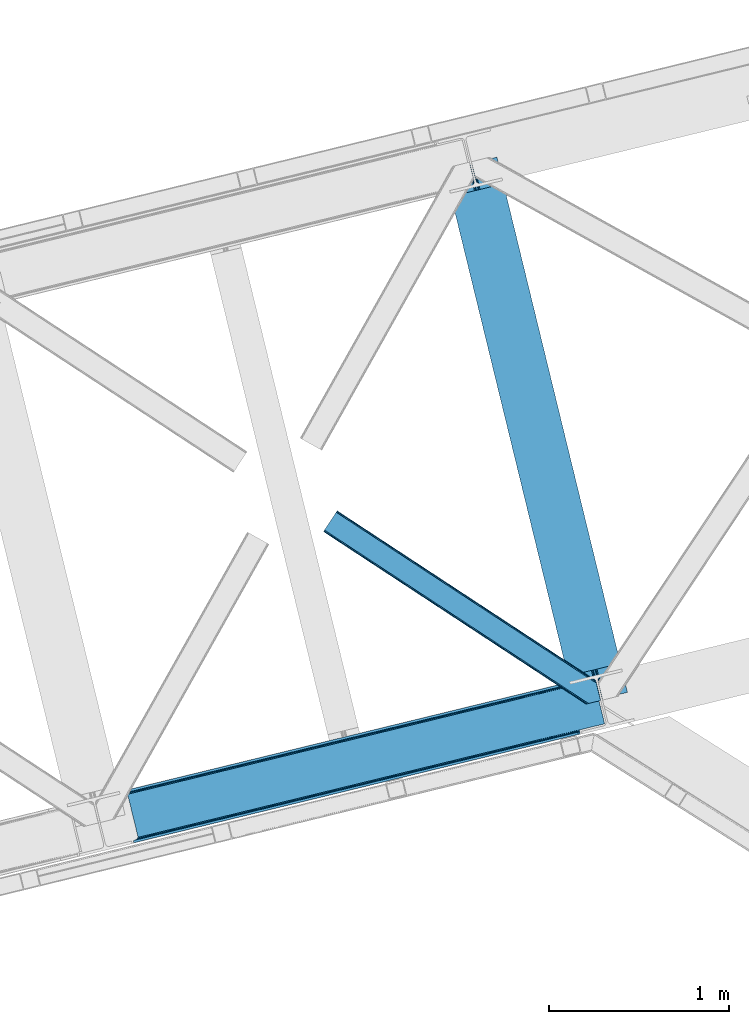
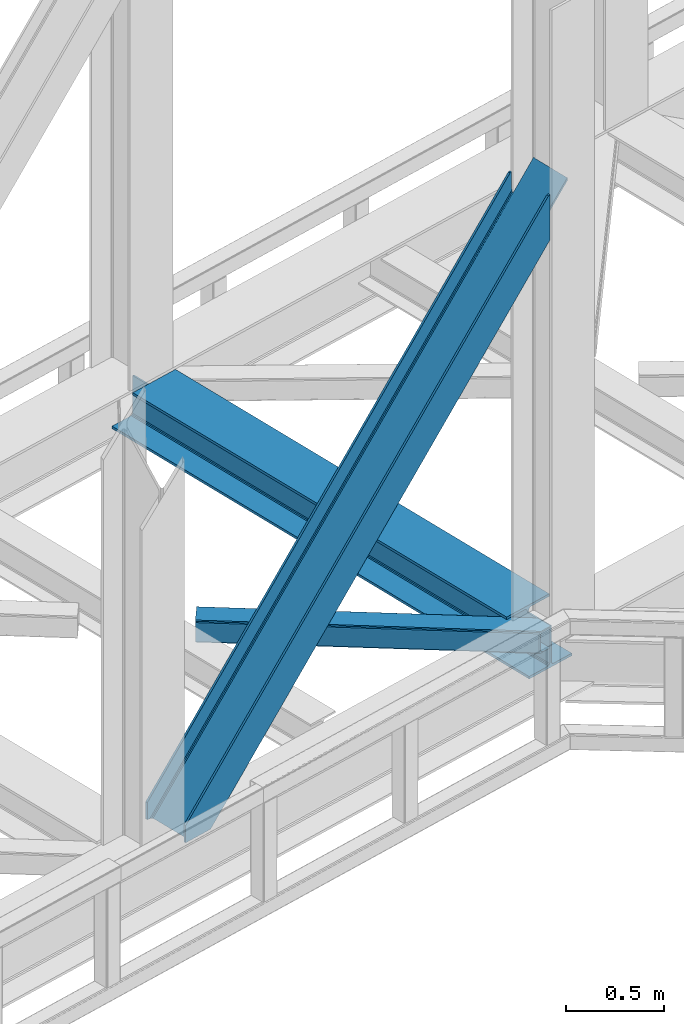
# One storey, part 80 of 92: 2 members, 1 beam.
"""IFC4 building model written with IfcOpenShell, lengths in millimetres."""

from ifc_helpers import new_model, entity, si_unit, converted_unit, derived_unit, direction, frame, origin, place, context, subcontext, project, spatial, triangles, polygons, material, type_object, element, save


model = new_model("IFC4")

# Units and contexts
model_context = context("Model", 3, precision=0.01, world=origin(), true_north=direction((6.12303176911189e-17, 1.0)))
plan_context = context("Plan", 3, precision=0.01, world=origin(), true_north=direction((6.12303176911189e-17, 1.0)))
body_context = subcontext(model_context, "Body", "Model", "MODEL_VIEW")
ifc_project = project(units=[si_unit("LENGTHUNIT", "METRE", prefix="MILLI"), si_unit("AREAUNIT", "SQUARE_METRE"), si_unit("VOLUMEUNIT", "CUBIC_METRE"), converted_unit("PLANEANGLEUNIT", "DEGREE", entity("IfcRatioMeasure", 0.0174532925199433), si_unit("PLANEANGLEUNIT", "RADIAN"), dimensions=[0, 0, 0, 0, 0, 0, 0]), si_unit("MASSUNIT", "GRAM", prefix="KILO"), derived_unit("MASSDENSITYUNIT", [(si_unit("MASSUNIT", "GRAM", prefix="KILO"), 1), (si_unit("LENGTHUNIT", "METRE"), -3)]), derived_unit("MOMENTOFINERTIAUNIT", [(si_unit("LENGTHUNIT", "METRE"), 4)]), si_unit("TIMEUNIT", "SECOND"), si_unit("FREQUENCYUNIT", "HERTZ"), si_unit("THERMODYNAMICTEMPERATUREUNIT", "DEGREE_CELSIUS"), derived_unit("THERMALTRANSMITTANCEUNIT", [(si_unit("MASSUNIT", "GRAM", prefix="KILO"), 1), (si_unit("THERMODYNAMICTEMPERATUREUNIT", "KELVIN"), -1), (si_unit("TIMEUNIT", "SECOND"), -3)]), derived_unit("VOLUMETRICFLOWRATEUNIT", [(si_unit("LENGTHUNIT", "METRE"), 3), (si_unit("TIMEUNIT", "SECOND"), -1)]), derived_unit("MASSFLOWRATEUNIT", [(si_unit("MASSUNIT", "GRAM", prefix="KILO"), 1), (si_unit("TIMEUNIT", "SECOND"), -1)]), derived_unit("ROTATIONALFREQUENCYUNIT", [(si_unit("TIMEUNIT", "SECOND"), -1)]), si_unit("ELECTRICCURRENTUNIT", "AMPERE"), si_unit("ELECTRICVOLTAGEUNIT", "VOLT"), si_unit("POWERUNIT", "WATT"), si_unit("FORCEUNIT", "NEWTON", prefix="KILO"), si_unit("ILLUMINANCEUNIT", "LUX"), si_unit("LUMINOUSFLUXUNIT", "LUMEN"), si_unit("LUMINOUSINTENSITYUNIT", "CANDELA"), derived_unit("USERDEFINED", [(si_unit("MASSUNIT", "GRAM", prefix="KILO"), -1), (si_unit("LENGTHUNIT", "METRE"), -2), (si_unit("TIMEUNIT", "SECOND"), 3), (si_unit("LUMINOUSFLUXUNIT", "LUMEN"), 1)]), derived_unit("LINEARVELOCITYUNIT", [(si_unit("LENGTHUNIT", "METRE"), 1), (si_unit("TIMEUNIT", "SECOND"), -1)]), si_unit("PRESSUREUNIT", "PASCAL"), derived_unit("USERDEFINED", [(si_unit("LENGTHUNIT", "METRE"), -2), (si_unit("MASSUNIT", "GRAM", prefix="KILO"), 1), (si_unit("TIMEUNIT", "SECOND"), -2)]), derived_unit("LINEARFORCEUNIT", [(si_unit("MASSUNIT", "GRAM", prefix="KILO"), 1), (si_unit("LENGTHUNIT", "METRE"), 1), (si_unit("TIMEUNIT", "SECOND"), -2), (si_unit("LENGTHUNIT", "METRE"), -1)]), derived_unit("PLANARFORCEUNIT", [(si_unit("MASSUNIT", "GRAM", prefix="KILO"), 1), (si_unit("LENGTHUNIT", "METRE"), 1), (si_unit("TIMEUNIT", "SECOND"), -2), (si_unit("LENGTHUNIT", "METRE"), -2)])], contexts=[model_context, plan_context])

# Site, building, storey
site_placement = place(None, origin())
site = spatial("IfcSite", under=ifc_project, at=site_placement, CompositionType="ELEMENT")
building_placement = place(site_placement, origin())
building = spatial("IfcBuilding", under=site, at=building_placement, CompositionType="ELEMENT")
storey_placement = place(building_placement, frame((0.0, 0.0, 15900.0)))
storey = spatial("IfcBuildingStorey", under=building, at=storey_placement, Name="05", CompositionType="ELEMENT", Elevation=15900.0)

# Beam
ifc_material = material(Name="Metal painted (White)")
beam_type = type_object("IfcBeamType", PredefinedType="BEAM")
beam_placement = place(storey_placement, frame((-6288.26, 16262.1, 3385.0)))
element("IfcBeam", 1, at=beam_placement, inside=storey, type_object=beam_type, material=ifc_material, ObjectType="Steel Beam", PredefinedType="BEAM", context=body_context, shape_type="Tessellation", body=[
    polygons([(1018.1664837833, 71.0478278971021, 15.4999999999986), (1018.1664837833, 71.0478278971021, 0.0), (291.465617442446, 3052.25531830421, 0.0), (291.465617442446, 3052.25531830421, 15.4999999999986), (894.779372399328, 40.970914087327, 15.4999999999986), (168.078506058477, 3022.17840449444, 15.4999999999986), (888.08702862538, 39.3395844888265, 16.8701684147941), (161.386162284531, 3020.54707489594, 16.8701684147941), (882.413533524756, 37.956610033654, 20.7720779386456), (155.712667183905, 3019.16410044077, 20.7720779386456), (878.622625296182, 37.0325360459184, 26.6116982174294), (151.921758955332, 3018.24002645303, 26.6116982174294), (877.291435352789, 36.7080444135029, 33.500000000001), (150.590569011938, 3017.91553482062, 33.500000000001), (140.875048430522, 3015.54727389071, 33.500000000001), (140.875048430529, 3015.54727389071, 259.000000000002), (150.590569011936, 3017.91553482062, 259.000000000002), (0.0, 2981.20749040711, 0.0), (3.24860138789518e-12, 2981.20749040711, 15.4999999999986), (123.387111383973, 3011.28440421689, 15.4999999999986), (130.07945515793, 3012.91573381539, 16.8701684147963), (135.752950258543, 3014.29870827056, 20.7720779386413), (139.543858487125, 3015.2227822583, 26.6116982174294), (877.291435352786, 36.7080444135051, 259.000000000002), (867.575914771381, 34.3397834836014, 259.000000000002), (867.575914771373, 34.3397834836014, 33.500000000001), (866.244724827976, 34.0152918511859, 26.6116982174294), (862.453816599394, 33.0912178634502, 20.7720779386413), (856.780321498779, 31.70824340828, 16.8701684147963), (850.087977724824, 30.076913809773, 15.4999999999986), (726.700866340854, 0.0, 15.4999999999986), (726.700866340851, 0.0, 0.0), (838.124523615913, 197.385937999179, 259.069791973884), (186.469722099971, 2870.72539801218, 259.000000000002), (186.693115201822, 2869.8089536072, 259.61730333112), (186.70550404545, 2869.75812937344, 266.500003008253), (837.979344808147, 197.981416001706, 266.500002998871), (837.979694928899, 197.979979696973, 260.000004007589), (828.499586345894, 194.645865944436, 259.006343171919), (828.276216326132, 195.562317481916, 259.61730333112), (828.263827482503, 195.613141715689, 266.500003008253), (176.989986719804, 2867.38985508742, 266.500002998871), (176.989636599053, 2867.39129139215, 260.000004007589), (176.844830940719, 2867.98534020595, 259.07612046749), (176.75420151856, 2868.35713708228, 259.000000000002), (839.310832678078, 198.30468544639, 273.388305639783), (843.101109266765, 199.231350618303, 279.227924098781), (848.774180214308, 200.616065081983, 283.129832400619), (855.466371895431, 202.248018612794, 284.500000377224), (978.853400583268, 232.325271667905, 284.500000138971), (978.851730776622, 232.332121736639, 299.999995328161), (687.386308679347, 161.283492472594, 299.999995890962), (687.387978486002, 161.276642403863, 284.500000701776), (810.77500717385, 191.353895458972, 284.500000463519), (817.467494069993, 192.984637925553, 283.129832461069), (823.141405718744, 194.365903570079, 279.227924137322), (826.932940505748, 195.287407219375, 273.388305663684), (175.658498849865, 2867.06658564273, 273.388305639783), (171.868222261161, 2866.13992047082, 279.227924098781), (166.195151313634, 2864.75520600714, 283.129832400619), (159.502959632503, 2863.12325247633, 284.500000377228), (36.1159309446587, 2833.04599942122, 284.500000138971), (36.117600751305, 2833.03914935249, 299.999995328161), (327.583022848579, 2904.08777861653, 299.999995890962), (327.581353041926, 2904.09462868526, 284.500000701776), (204.194324354083, 2874.01737563015, 284.500000463519), (197.501837457949, 2872.38663316357, 283.129832461069), (191.827925809181, 2871.00536751904, 279.227924137318), (188.036391022195, 2870.08386386975, 273.388305663684)], [[[1, 2, 3, 4]], [[5, 1, 4, 6]], [[7, 5, 6, 8]], [[9, 7, 8, 10]], [[11, 9, 10, 12]], [[13, 11, 12, 14]], [[15, 16, 17, 14, 12, 10, 8, 6, 4, 3, 18, 19, 20, 21, 22, 23]], [[13, 24, 25, 26, 27, 28, 29, 30, 31, 32, 2, 1, 5, 7, 9, 11]], [[2, 32, 18, 3]], [[32, 31, 19, 18]], [[31, 30, 20, 19]], [[27, 26, 15, 23]], [[28, 27, 23, 22]], [[29, 28, 22, 21]], [[30, 29, 21, 20]], [[33, 24, 13, 14, 17, 34, 35, 36, 37, 38]], [[25, 39, 40, 41, 42, 43, 44, 16, 15, 26]], [[39, 25, 24, 33]], [[45, 34, 17, 16]], [[41, 40, 38, 37, 46, 47, 48, 49, 50, 51, 52, 53, 54, 55, 56, 57]], [[42, 58, 59, 60, 61, 62, 63, 64, 65, 66, 67, 68, 69, 36, 35, 43]], [[46, 37, 36, 69]], [[47, 46, 69, 68]], [[48, 47, 68, 67]], [[49, 48, 67, 66]], [[50, 49, 66, 65]], [[51, 50, 65, 64]], [[52, 51, 64, 63]], [[53, 52, 63, 62]], [[54, 53, 62, 61]], [[55, 54, 61, 60]], [[56, 55, 60, 59]], [[57, 56, 59, 58]], [[41, 57, 58, 42]]], closed=False),
])

# Members
member_type_1 = type_object("IfcMemberType", PredefinedType="BRACE")
member_1_placement = place(storey_placement, frame((-8089.65, 15494.85, 3695.0)))
element("IfcMember", 2, at=member_1_placement, inside=storey, type_object=member_type_1, ObjectType="Steel Vertical Brace", PredefinedType="BRACE", context=body_context, shape_type="Tessellation", body=[
    polygons([(1.40772726808791e-11, 286.607857151674, 3.46517481375486e-11), (3.07873920888844, 273.977680395838, 3.46517481375486e-11), (3.07873920887978, 273.977680395836, 106.657658279548), (5.41433564649196e-12, 286.607857151672, 106.657658279548), (2479.77214765692, 877.697901605291, 2779.57626168546), (2490.25200805115, 880.25247845112, 2781.68279398581), (2487.17326884228, 892.882655206959, 2781.68279398581), (2476.69340844805, 890.328078361125, 2779.57626168546), (2487.17326884232, 892.882655206967, 2501.09970740483), (169.685130105999, 327.970402848329, 8.66293703438714e-12), (8.63541989629372, 275.332180101914, 3.0320279620355e-11), (433.383301583627, 378.868970007297, 458.400103479437), (873.798113333203, 486.224739868203, 933.708407497008), (1314.21292508278, 593.58050972911, 1409.01671151459), (1754.62773683235, 700.936279590014, 1884.32501553215), (2195.04254858192, 808.292049450921, 2359.63331954974), (2490.25200805115, 880.25247845112, 2678.23184023267), (2492.62026898092, 870.536957869704, 2654.86848791588), (2492.62026898094, 870.53695786971, 2637.11764726648), (2491.50057367132, 875.130380279155, 2632.19620890634), (2490.57649968358, 878.921288507726, 2623.73498686228), (2490.25200805117, 880.252478451127, 2613.75429494974), (2490.25200805119, 880.252478451131, 2501.09970740482), (2490.57649968356, 878.921288507724, 2668.25114832013), (2491.50057367131, 875.130380279151, 2659.78992627607), (172.763869314872, 315.340226092493, 1.29944055515807e-11), (68.3795180486662, 289.895436106668, 2.16573425859679e-11), (59.456023663077, 286.309951729616, 2.16573425859679e-11), (52.5400336708518, 280.607944959686, 2.16573425859679e-11), (48.6844448546849, 273.657494638771, 2.59888111031614e-11), (48.4762356608549, 266.516743822247, 2.59888111031614e-11), (103.656715327596, 40.145114275335, 2.16573425859679e-11), (107.127583718431, 33.9011775439468, 2.59888111031614e-11), (113.74912144494, 29.5046376636216, 2.16573425859679e-11), (122.513259412632, 27.6248279764103, 2.16573425859679e-11), (132.085737063049, 28.547932466671, 2.16573425859679e-11), (236.47008832926, 53.9927224524939, 1.29944055515807e-11), (239.548827538132, 41.3625456966575, 1.29944055515807e-11), (69.8636974321611, 6.49720277579036e-12, 2.59888111031614e-11), (66.7849582232867, 12.6301767558429, 2.59888111031614e-11), (72.341638910679, 13.9846764619192, 2.59888111031614e-11), (81.2651332962692, 17.5701608389667, 2.59888111031614e-11), (88.1811232884945, 23.2721676088969, 2.16573425859679e-11), (92.0367121046646, 30.2226179298118, 2.16573425859679e-11), (92.2449212984827, 37.3633687463359, 2.16573425859679e-11), (37.0644416317488, 263.734998293248, 2.16573425859679e-11), (33.5935732409145, 269.978935024638, 2.59888111031614e-11), (26.9720355144061, 274.375474904959, 2.59888111031614e-11), (18.2078975467106, 276.255284592173, 2.59888111031614e-11), (2222.97764830487, 815.101525555926, 2325.30413557899), (1786.65153917478, 708.742420216138, 1854.40847676737), (1350.32543004469, 602.383314876352, 1383.51281795575), (913.999320914596, 496.024209536566, 912.617159144125), (477.673211784489, 389.665104196776, 441.721500332495), (904.938963351586, 482.378592516797, 924.094449451842), (905.606971778072, 475.451429015422, 925.040088653682), (469.280862647981, 369.092323675639, 454.144429842066), (468.61285422149, 376.019487177011, 453.198790640217), (1341.26507248168, 588.737697856582, 1394.99010826347), (1341.93308090817, 581.81053435521, 1395.93574746531), (1777.59118161177, 695.09680319637, 1865.88576707508), (1778.25919003826, 688.169639694996, 1866.83140627693), (2213.91729074187, 801.455908536156, 2336.78142588671), (2214.58529916835, 794.528745034784, 2337.72706508856), (906.299295496554, 488.720797624809, 921.401496842536), (469.973186366456, 382.361692285026, 450.505838030915), (1342.62540462664, 595.079902964597, 1392.29715565416), (1778.95151375674, 701.439008304385, 1863.19281446579), (2215.27762288683, 807.798113644168, 2334.08847327741), (909.480869975335, 493.512501104002, 917.371208448875), (473.154760845237, 387.153395764214, 446.475549637249), (1345.80697910543, 599.871606443792, 1388.2668672605), (1782.13308823552, 706.230711783578, 1859.16252607212), (2218.45919736561, 812.589817123363, 2330.05818488374), (2633.7716358821, 903.743176316807, 2789.55036821224), (2635.38992615546, 897.104324888169, 2791.8714949306), (2633.49531741138, 904.876741353294, 2789.15404241362), (878.96554753729, 486.074068413974, 928.954358192258), (438.550735787722, 378.718298553068, 453.646054174687), (1319.38035928687, 593.429838274884, 1404.26266220984), (1759.79517103644, 700.785608135789, 1879.57096622741), (2200.20998278601, 808.141377996695, 2354.87927024499), (883.995269991544, 483.283955436023, 924.924069798597), (443.580458241977, 375.928185575115, 449.615765781021), (1324.41008174112, 590.639725296929, 1400.23237381616), (1764.8248934907, 697.995495157838, 1875.54067783375), (2205.23970524027, 805.351265018742, 2350.84898185132), (888.121551046853, 478.279170342798, 922.231117189295), (447.706739297282, 370.923400481892, 446.92281317172), (1328.53636279643, 585.63494020371, 1397.53942120687), (1768.951174546, 692.990710064611, 1872.84772522445), (2209.36598629557, 800.346479925519, 2348.15602924201), (890.71620181737, 471.821646296262, 921.285477987442), (450.301390067803, 364.465876435356, 445.977173969866), (1331.13101356694, 579.177416157165, 1396.59378200502), (1771.54582531652, 686.53318601807, 1871.9020860226), (2211.96063706608, 793.888955878978, 2347.21039004016), (2635.38992615546, 897.104324888172, 2804.18743054644), (2633.77163588193, 903.743176316768, 2806.50855726461), (2633.49531741138, 904.876741353292, 2806.90488306303), (2692.46501456604, 662.96027887608, 2789.1540424138), (2692.18869609554, 664.093843912616, 2789.55036821219), (2690.57040582217, 670.732695341253, 2791.87149493059), (2690.57040582218, 670.732695341255, 2804.18743054644), (2692.18869609558, 664.093843912622, 2806.50855726476), (2692.46501456604, 662.96027887608, 2806.90488306319), (2269.76577883509, 568.157115487872, 2337.72706508856), (1833.439669705, 461.798010148086, 1866.83140627693), (1397.11356057491, 355.438904808298, 1395.9357474653), (960.787451444811, 249.079799468513, 925.040088653678), (524.461342314724, 142.720694128725, 454.144429842061), (505.481869734545, 138.09424688844, 445.977173969879), (945.89668148413, 245.45001674935, 921.285477987468), (1386.31149323372, 352.805786610262, 1396.59378200506), (1826.72630498331, 460.161556471171, 1871.90208602265), (2267.14111673289, 567.517326332079, 2347.21039004024), (972.538105724893, 234.827377350796, 917.371208448875), (977.70553992898, 234.676705896572, 912.617159144125), (541.379430798871, 128.317600556782, 441.721500332495), (536.211996594793, 128.468272011006, 446.475549637249), (1408.86421485499, 341.186482690586, 1388.2668672605), (1414.03164905907, 341.035811236355, 1383.51281795575), (1845.19032398508, 447.545588030369, 1859.16252607212), (1850.35775818916, 447.394916576143, 1854.40847676737), (2281.51643311517, 553.904693370155, 2330.05818488374), (2286.68386731925, 553.754021915929, 2325.30413557899), (967.50838327064, 237.617490328749, 921.401496842536), (531.182274140543, 131.258384988961, 450.505838030919), (1403.83449240073, 343.976595668537, 1392.29715565416), (1840.16060153083, 450.335701008325, 1863.19281446579), (2276.48671066093, 556.69480634811, 2334.08847327741), (963.382102215336, 242.622275421974, 924.094449451838), (527.055993085239, 136.263170082187, 453.198790640217), (1399.70821134542, 348.981380761758, 1394.99010826347), (1836.03432047551, 455.340486101544, 1865.88576707509), (2272.36042960562, 561.699591441334, 2336.78142588671), (2552.70966144542, 624.027072983099, 2632.19620890634), (2553.63373543315, 620.236164754529, 2623.73498686228), (2553.95822706556, 618.90497481113, 2613.75429494974), (2551.58996613545, 628.620495392468, 2637.11764726648), (946.564689910631, 238.52285324798, 922.231117189325), (506.149878161041, 131.16708338707, 446.922813171728), (1386.97950166022, 345.878623108894, 1397.53942120691), (1827.3943134098, 453.234392969802, 1872.8477252245), (2267.80912515938, 560.590162830712, 2348.15602924209), (945.204357765662, 232.180648139967, 924.924069798623), (504.789546016076, 124.82487827906, 449.61576578103), (1385.61916951524, 339.536418000875, 1400.23237381621), (1826.03398126484, 446.892187861787, 1875.5406778338), (2266.44879301443, 554.247957722706, 2350.8489818514), (942.022783286881, 227.388944660777, 928.954358192284), (501.607971537291, 120.033174799865, 453.6460541747), (1382.43759503646, 334.744714521684, 1404.26266220988), (1822.85240678605, 442.100484382596, 1879.57096622747), (2263.26721853563, 549.456254243506, 2354.87927024505), (937.504332347626, 224.877236228214, 933.708407497034), (497.089520598031, 117.5214663673, 458.40010347945), (1377.91914409721, 332.233006089122, 1409.01671151463), (1818.33395584679, 439.588775950032, 1884.32501553222), (2258.74876759638, 546.944545810944, 2359.6333195498), (2553.95822706554, 618.904974811123, 2678.23184023267), (2553.63373543312, 620.236164754518, 2668.25114832012), (2552.70966144542, 624.027072983099, 2659.78992627607), (2551.58996613546, 628.620495392464, 2654.86848791588), (2553.95822706551, 618.904974811119, 2781.68279398581), (2557.03696627439, 606.274798055283, 2781.68279398581), (2557.03696627445, 606.274798055295, 2501.09970740482), (2553.95822706557, 618.904974811132, 2501.09970740483), (66.784958223264, 12.6301767558364, 106.657658279548), (2543.47836667131, 616.350397965292, 2779.57626168546), (69.8636974321384, 0.0, 106.657658279548), (2546.55710588018, 603.720221209456, 2779.57626168546)], [[[1, 2, 3, 4]], [[5, 6, 7, 8]], [[4, 3, 5, 8]], [[1, 4, 8, 7, 9, 10]], [[3, 2, 11, 12, 13, 14, 15, 16, 17, 6, 5]], [[18, 19, 20, 21, 22, 23, 9, 7, 6, 17, 24, 25]], [[2, 1, 10, 26, 27, 28, 29, 30, 31, 32, 33, 34, 35, 36, 37, 38, 39, 40, 41, 42, 43, 44, 45, 46, 47, 48, 49, 11]], [[10, 9, 23, 26]], [[26, 23, 22, 50, 51, 52, 53, 54, 27]], [[55, 56, 57, 58]], [[59, 60, 56, 55]], [[61, 62, 60, 59]], [[63, 64, 62, 61]], [[65, 55, 58, 66]], [[67, 59, 55, 65]], [[68, 61, 59, 67]], [[69, 63, 61, 68]], [[70, 65, 66, 71]], [[72, 67, 65, 70]], [[73, 68, 67, 72]], [[74, 69, 68, 73]], [[53, 70, 71, 54]], [[52, 72, 70, 53]], [[51, 73, 72, 52]], [[50, 74, 73, 51]], [[64, 75, 76]], [[31, 30, 58, 57]], [[30, 29, 66, 58]], [[29, 28, 71, 66]], [[28, 27, 54, 71]], [[22, 21, 74, 50]], [[21, 20, 69, 74]], [[75, 19, 77]], [[63, 20, 19]], [[20, 63, 69]], [[19, 75, 63]], [[75, 64, 63]], [[78, 13, 12, 79]], [[80, 14, 13, 78]], [[81, 15, 14, 80]], [[82, 16, 15, 81]], [[83, 78, 79, 84]], [[85, 80, 78, 83]], [[86, 81, 80, 85]], [[87, 82, 81, 86]], [[88, 83, 84, 89]], [[90, 85, 83, 88]], [[91, 86, 85, 90]], [[92, 87, 86, 91]], [[93, 88, 89, 94]], [[95, 90, 88, 93]], [[96, 91, 90, 95]], [[97, 92, 91, 96]], [[92, 98, 99]], [[25, 24, 82, 87]], [[24, 17, 16, 82]], [[11, 49, 79, 12]], [[49, 48, 84, 79]], [[48, 47, 89, 84]], [[47, 46, 94, 89]], [[18, 99, 100]], [[87, 18, 25]], [[92, 18, 87]], [[18, 92, 99]], [[98, 92, 97]], [[100, 77, 19, 18]], [[101, 102, 103, 76, 75, 77, 100, 99, 98, 104, 105, 106]], [[31, 57, 56, 60, 62, 64, 76, 103, 107, 108, 109, 110, 111, 32]], [[45, 112, 113, 114, 115, 116, 104, 98, 97, 96, 95, 93, 94, 46]], [[117, 118, 119, 120]], [[121, 122, 118, 117]], [[123, 124, 122, 121]], [[125, 126, 124, 123]], [[127, 117, 120, 128]], [[129, 121, 117, 127]], [[130, 123, 121, 129]], [[131, 125, 123, 130]], [[132, 127, 128, 133]], [[134, 129, 127, 132]], [[135, 130, 129, 134]], [[136, 131, 130, 135]], [[110, 132, 133, 111]], [[109, 134, 132, 110]], [[108, 135, 134, 109]], [[107, 136, 135, 108]], [[107, 102, 136]], [[137, 138, 125, 131]], [[138, 139, 126, 125]], [[36, 35, 120, 119]], [[35, 34, 128, 120]], [[34, 33, 133, 128]], [[33, 32, 111, 133]], [[140, 102, 101]], [[131, 140, 137]], [[136, 140, 131]], [[140, 136, 102]], [[102, 107, 103]], [[141, 113, 112, 142]], [[143, 114, 113, 141]], [[144, 115, 114, 143]], [[145, 116, 115, 144]], [[146, 141, 142, 147]], [[148, 143, 141, 146]], [[149, 144, 143, 148]], [[150, 145, 144, 149]], [[151, 146, 147, 152]], [[153, 148, 146, 151]], [[154, 149, 148, 153]], [[155, 150, 149, 154]], [[156, 151, 152, 157]], [[158, 153, 151, 156]], [[159, 154, 153, 158]], [[160, 155, 154, 159]], [[145, 104, 116]], [[45, 44, 142, 112]], [[44, 43, 147, 142]], [[43, 42, 152, 147]], [[42, 41, 157, 152]], [[161, 162, 155, 160]], [[162, 163, 150, 155]], [[105, 164, 106]], [[150, 164, 145]], [[164, 150, 163]], [[164, 105, 145]], [[104, 145, 105]], [[164, 140, 101, 106]], [[161, 165, 166, 167, 168, 139, 138, 137, 140, 164, 163, 162]], [[36, 119, 118, 122, 124, 126, 139, 168, 37]], [[37, 168, 167, 38]], [[40, 169, 170, 165, 161, 160, 159, 158, 156, 157, 41]], [[171, 39, 38, 167, 166, 172]], [[40, 39, 171, 169]], [[172, 166, 165, 170]], [[169, 171, 172, 170]]], closed=True),
])
member_type_2 = type_object("IfcMemberType", PredefinedType="BRACE")
member_2_placement = place(storey_placement, frame((-6963.31, 16267.7, 3510.0)))
element("IfcMember", 3, at=member_2_placement, inside=storey, type_object=member_type_2, ObjectType="Steel Horizontal Brace", PredefinedType="BRACE", context=body_context, shape_type="Tessellation", body=[
    triangles([(1516.36267547607, 132.252392578126, 122.500662231447), (1516.36267547607, 132.252392578126, 17.5000946044929), (76.8296127319336, 1077.23657226563, 122.500662231447), (76.8296127319336, 1077.23657226563, 17.5000946044929), (1516.82485656738, 130.355996704102, 129.197927856447), (76.0959365844728, 1076.12152404785, 129.197927856447), (1518.14163665772, 124.952838134765, 134.874325561526), (74.0158309936523, 1072.95078735352, 134.874325561526), (1520.11244659424, 116.868447875977, 138.667117309571), (70.8979980468748, 1068.20456542969, 138.667117309571), (1522.4373046875, 107.330657958984, 139.999594116212), (67.2267105102537, 1062.60723266602, 139.999594116212), (9.60348358154261, 974.828869628907, 139.999594116212), (1485.96860046387, 5.66825866699219, 139.999594116212), (1543.78367614746, 19.761584472657, 139.999594116212), (1477.07146911621, 3.49978637695313, 138.667117309571), (5.92754516601508, 969.230374145509, 138.667117309571), (1469.52541809082, 1.66036376953161, 134.874325561526), (2.81436309814399, 964.485314941407, 134.874325561526), (1464.48735351562, 0.431369018555415, 129.197927856447), (0.729606628417969, 961.313415527346, 129.197927856447), (1462.71595001221, 0.0, 122.500662231447), (0.0, 960.199530029297, 122.500662231447), (1462.71595001221, 0.0, 17.5000946044929), (0.0, 960.199530029297, 17.5000946044929), (1516.61382293701, 131.222222900391, 12.5201660156272), (1515.01508331299, 131.201293945314, 10.9621215820334), (76.0959365844728, 1076.12152404785, 10.8028289794929), (1387.90133056641, 210.37553100586, 5.21247253418187), (74.0158309936523, 1072.95078735352, 5.12526855468968), (1509.43170318603, 131.129205322266, 5.52059326172093), (1380.44132080078, 208.557037353517, 1.33247680664135), (1371.53953857422, 206.387402343751, 0.0), (70.8979980468748, 1068.20456542969, 1.33247680664135), (67.2267105102537, 1062.60723266602, 0.0), (1375.835206604, 62.7054748535156, 5.51129150390625), (1387.90133056641, 210.37553100586, 5.38222961426072), (1509.43170318603, 131.129205322266, 5.43687744140698), (1342.53491363525, 199.316903686524, 5.39734497070458), (1469.0190536499, 1.53595275878979, 5.55431213379052), (1536.9829284668, 18.1035461425781, 5.53222045898656), (0.729606628417969, 961.313415527346, 10.8028289794929), (2.81436309814399, 964.485314941407, 5.12526855468968), (1375.04339447021, 63.8333129882813, 5.02062377929906), (5.92754516601508, 969.230374145509, 1.33247680664135), (1372.50634002686, 72.1397827148448, 1.33247680664135), (1374.25623321533, 64.9611511230469, 4.52065429687718), (1370.18148193359, 81.6775726318356, 0.0), (9.60348358154261, 974.828869628907, 0.0), (1464.48735351562, 0.431369018555415, 10.8028289794929), (1469.0190536499, 1.53595275878979, 5.52059326172093), (1375.835206604, 62.7054748535156, 5.52059326172093), (1341.56346130371, 199.079708862306, 0.0), (1342.53491363525, 199.316903686524, 5.52059326172093), (1341.56346130371, 199.079708862306, 4.52065429687718), (1520.4391708374, 115.528994750977, 12.5201660156272), (1517.40854187012, 110.267687988282, 8.3320495605476), (1538.42005004883, 18.4535247802742, 6.99957275390625), (1536.9829284668, 18.1035461425781, 5.52059326172093), (1518.10268554687, 101.803088378907, 6.99957275390625), (13.447434997558, 980.682000732422, 6.99957275390625), (63.3827590942383, 1056.7541015625, 6.99957275390625), (1495.27210235596, 7.93556213378906, 6.99957275390625), (67.0586975097658, 1062.3525970459, 8.3320495605476), (70.1718795776369, 1067.09881896973, 12.1260040283232), (1519.2549407959, 120.386837768556, 17.8035644531265), (1518.79217834473, 122.284396362304, 24.4996673583992), (72.2566360473629, 1070.27071838379, 17.8035644531265), (72.9856613159182, 1071.38344116211, 24.4996673583992), (1518.79217834473, 122.284396362304, 115.501089477541), (72.9856613159182, 1071.38344116211, 115.501089477541), (1520.57172088623, 114.984841918946, 127.87475280762), (1519.2549407959, 120.386837768556, 122.196029663086), (1524.86738891602, 97.3626617431637, 133.000021362306), (1522.54253082275, 106.899288940431, 131.667544555665), (1543.78367614746, 19.761584472657, 133.000021362306), (63.3827590942383, 1056.7541015625, 133.000021362306), (67.0586975097658, 1062.3525970459, 131.667544555665), (70.1718795776369, 1067.09881896973, 127.87475280762), (72.2566360473629, 1070.27071838379, 122.196029663086), (13.447434997558, 980.682000732422, 133.000021362306), (1495.27210235596, 7.93556213378906, 133.000021362306), (6.65366363525391, 970.336120605471, 12.1260040283232), (9.77149658203143, 975.082342529297, 8.3320495605476), (3.83988189697266, 966.051498413088, 24.4996673583992), (4.57355804443341, 967.165383911133, 17.8035644531265), (6.65366363525391, 970.336120605471, 127.87475280762), (9.77149658203143, 975.082342529297, 131.667544555665), (3.83988189697266, 966.051498413088, 115.501089477541), (4.57355804443341, 967.165383911133, 122.196029663086), (1478.82891998291, 3.92766723632849, 127.87475280762), (1486.37032012939, 5.76592712402453, 131.667544555665), (1473.78620452881, 2.69867248535229, 122.196029663086), (1472.01480102539, 2.26730346679688, 115.501089477541), (1472.01480102539, 2.26730346679688, 24.4996673583992), (1478.82891998291, 3.92766723632849, 12.1260040283232), (1473.78620452881, 2.69867248535229, 17.8035644531265), (1486.37032012939, 5.76592712402453, 8.3320495605476)], [[1, 2, 3], [4, 3, 2], [5, 1, 6], [3, 6, 1], [7, 5, 8], [6, 8, 5], [9, 7, 10], [8, 10, 7], [11, 9, 12], [10, 12, 9], [13, 11, 12], [11, 13, 14], [15, 11, 14], [16, 14, 13], [13, 17, 16], [18, 16, 17], [17, 19, 18], [20, 18, 19], [19, 21, 20], [22, 20, 21], [21, 23, 22], [24, 22, 25], [23, 25, 22], [4, 26, 27], [4, 2, 26], [28, 27, 29], [29, 30, 28], [27, 31, 29], [30, 29, 32], [32, 33, 34], [35, 34, 33], [32, 34, 30], [27, 28, 4], [36, 37, 38], [37, 36, 39], [38, 40, 36], [41, 40, 38], [42, 43, 44], [43, 45, 46], [46, 47, 43], [47, 44, 43], [48, 46, 45], [45, 49, 48], [50, 24, 42], [25, 42, 24], [51, 50, 52], [42, 52, 50], [53, 35, 33], [49, 53, 48], [53, 49, 35], [33, 54, 53], [29, 33, 32], [53, 54, 55], [29, 54, 33], [48, 55, 47], [48, 53, 55], [47, 46, 48], [56, 31, 27], [57, 31, 56], [27, 26, 56], [58, 59, 60], [60, 31, 57], [31, 60, 59], [61, 60, 62], [60, 61, 63], [58, 60, 63], [64, 57, 56], [65, 56, 66], [66, 67, 68], [69, 68, 67], [66, 68, 65], [56, 65, 64], [60, 57, 62], [64, 62, 57], [67, 70, 71], [71, 69, 67], [72, 7, 9], [7, 72, 73], [74, 75, 11], [75, 72, 9], [76, 74, 15], [11, 15, 74], [75, 9, 11], [26, 66, 56], [2, 1, 67], [67, 66, 2], [26, 2, 66], [1, 70, 67], [73, 5, 7], [1, 5, 73], [70, 1, 73], [75, 74, 77], [77, 78, 75], [72, 75, 78], [78, 79, 72], [73, 72, 79], [79, 80, 73], [70, 73, 80], [80, 71, 70], [81, 74, 82], [81, 77, 74], [74, 76, 82], [28, 65, 68], [69, 3, 4], [28, 68, 4], [28, 30, 65], [68, 69, 4], [65, 30, 34], [62, 35, 49], [35, 64, 34], [64, 35, 62], [64, 65, 34], [6, 79, 8], [71, 3, 69], [3, 80, 6], [80, 3, 71], [6, 80, 79], [12, 77, 13], [10, 8, 79], [79, 78, 10], [78, 77, 12], [12, 10, 78], [83, 45, 43], [49, 61, 62], [49, 84, 61], [84, 49, 45], [83, 84, 45], [85, 25, 23], [42, 86, 83], [43, 42, 83], [86, 42, 25], [85, 86, 25], [17, 87, 19], [13, 77, 81], [81, 88, 13], [88, 87, 17], [17, 13, 88], [21, 19, 87], [23, 89, 85], [90, 23, 21], [23, 90, 89], [90, 21, 87], [91, 92, 16], [18, 91, 16], [93, 18, 20], [93, 22, 94], [18, 93, 91], [22, 93, 20], [92, 14, 16], [15, 82, 76], [15, 14, 82], [92, 82, 14], [22, 95, 94], [51, 96, 97], [97, 95, 24], [24, 95, 22], [97, 50, 51], [50, 97, 24], [59, 63, 51], [63, 98, 51], [98, 96, 51], [59, 58, 63], [93, 94, 90], [89, 90, 94], [91, 93, 87], [90, 87, 93], [92, 91, 88], [87, 88, 91], [82, 92, 81], [88, 81, 92], [94, 95, 85], [85, 89, 94], [98, 63, 61], [61, 84, 98], [96, 98, 84], [84, 83, 96], [97, 96, 83], [83, 86, 97], [95, 97, 86], [86, 85, 95]]),
])

save(model, "model.ifc")
